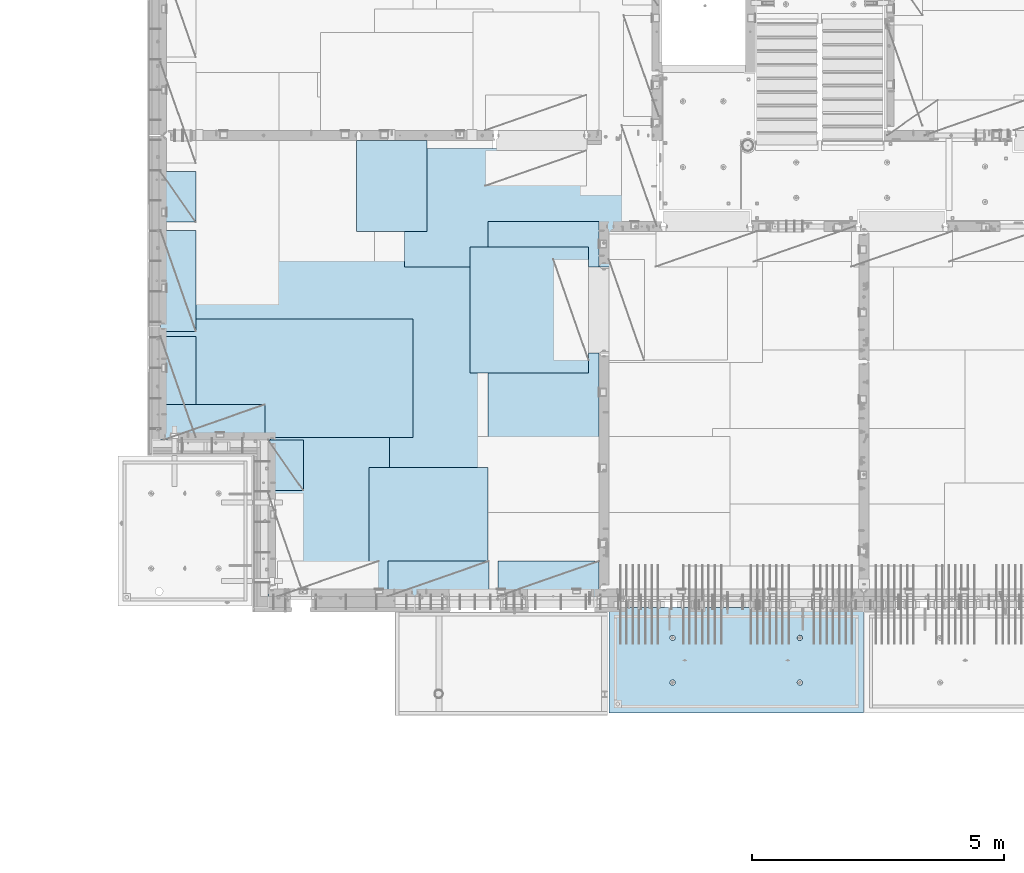
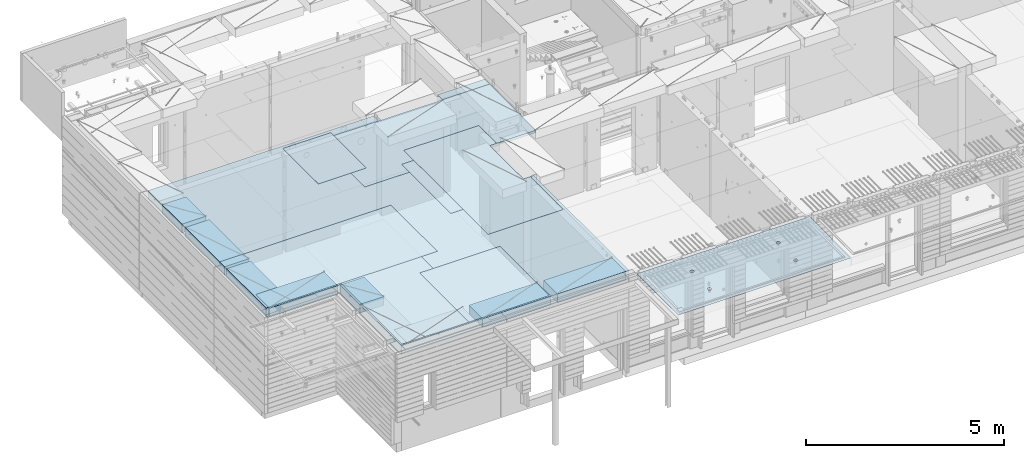
# One storey, part 179 of 325: 14 plates, 2 slabs, 14 elements without a shape of their own.
"""IFC2X3 building model written with IfcOpenShell, lengths in millimetres."""

from ifc_helpers import new_model, si_unit, frame, origin_with_axes, place, context, subcontext, project, spatial, faceted_brep, material, type_object, element, aggregate, save


model = new_model("IFC2X3")

# Units and contexts
model_context = context("Model", 3, precision=1e-05, world=origin_with_axes())
body_context = subcontext(model_context, "Body", "Model", "MODEL_VIEW")
ifc_project = project(units=[si_unit("LENGTHUNIT", "METRE", prefix="MILLI"), si_unit("AREAUNIT", "SQUARE_METRE"), si_unit("VOLUMEUNIT", "CUBIC_METRE"), si_unit("MASSUNIT", "GRAM", prefix="KILO"), si_unit("TIMEUNIT", "SECOND"), si_unit("PLANEANGLEUNIT", "RADIAN"), si_unit("SOLIDANGLEUNIT", "STERADIAN"), si_unit("THERMODYNAMICTEMPERATUREUNIT", "DEGREE_CELSIUS"), si_unit("LUMINOUSINTENSITYUNIT", "LUMEN")], contexts=[model_context])

# Site, building, storey
site_placement = place(None, origin_with_axes())
site = spatial("IfcSite", under=ifc_project, at=site_placement, CompositionType="ELEMENT")
building_placement = place(site_placement, origin_with_axes())
building = spatial("IfcBuilding", under=site, at=building_placement, CompositionType="ELEMENT")
storey_placement = place(building_placement, origin_with_axes())
storey = spatial("IfcBuildingStorey", under=building, at=storey_placement, Name="1", CompositionType="ELEMENT", Elevation=0.0)

# Assembly, slab
assembly_1_placement = place(storey_placement, origin_with_axes())
assembly_1 = element("IfcElementAssembly", 1, at=assembly_1_placement, inside=storey, AssemblyPlace="NOTDEFINED", PredefinedType="REINFORCEMENT_UNIT")
ifc_material_1 = material(Name="CONCRETE/C35/45")
slab_type_1 = type_object("IfcSlabType", PredefinedType="NOTDEFINED")
slab_1_placement = place(assembly_1_placement, frame((21799.9998568133, 7629.99655735226, 84720.0), z_axis=(-1.11800000013248e-06, -0.999999999999375, 0.0), x_axis=(-0.999999999999093, 1.34699999998405e-06, 0.0)))
slab_1 = element("IfcSlab", 2, at=slab_1_placement, type_object=slab_type_1, material=ifc_material_1, PredefinedType="FLOOR", context=body_context, shape_type="Brep", body=[
    faceted_brep([(3730.38290548735, -4.08996566387941, 616.12216176429), (3731.90567362447, 10.0, 615.627386703446), (3739.08833473806, 10.0, 629.724200466487), (3737.80580686752, -3.95055250760925, 630.656008831066), (3750.27560641379, 10.0, 640.911502705889), (3749.35118053074, -3.83997377335618, 642.183862123165), (3764.37240055375, 10.0, 648.094202331947), (3763.88889206625, -3.76900584615942, 649.582281527485), (3779.99882472937, 10.0, 650.569206660445), (3779.99882259584, -3.74455690493051, 652.131088126915), (3795.62525566664, 10.0, 648.094245023346), (3796.1087600739, -3.76900542440126, 649.582325494244), (3809.72206942968, 10.0, 640.911583909758), (3810.64649178305, -3.83997297089081, 642.183945778786), (3820.90937166908, 10.0, 629.724312234022), (3822.19189689232, -3.95055140258046, 630.656124028656), (3828.09207129514, 10.0, 615.627518094066), (3829.61483794004, -4.08996436404414, 616.122297269464), (3830.56707562364, 10.0, 600.001093918447), (3832.18578061358, -4.24460391153116, 600.001096129598), (3828.09211398654, 10.0, 584.374662981175), (3829.64831848373, -4.39934773846471, 583.869023838871), (3820.90945287295, 10.0, 570.277849218135), (3822.24608208202, -4.53903372617788, 569.306734043194), (3809.72218119721, 10.0, 559.090546978732), (3810.70070853473, -4.64994969953841, 557.743723511573), (3795.62538705726, 10.0, 551.907847352675), (3796.14233218844, -4.72119045964791, 550.316861227655), (3779.99896288164, 10.0, 549.432843024176), (3779.99896517058, -4.74574361447594, 547.757190340714), (3764.37253194437, 10.0, 551.907804661275), (3763.85559114489, -4.72119088313775, 550.316817078197), (3750.27571818133, 10.0, 559.090465774863), (3749.29719446955, -4.6499505048414, 557.743639560339), (3739.08841594193, 10.0, 570.277737450599), (3737.75178928409, -4.53903483404429, 569.306618549992), (3731.90571631587, 10.0, 584.374531590555), (3730.34951305942, -4.39934904004622, 583.868888150996), (3729.43071198737, 10.0, 600.000955766174), (3727.81200684201, -4.24460527917836, 600.000953555023), (0.0, 10.0, 0.0), (0.0, -10.0, 0.0), (0.000328360383718973, 10.0, 2085.00366210938), (5040.0, 10.0, -2.18278728425503e-09), (5040.0, -10.0, -2.18278728425503e-09), (5040.00048828125, 10.0, 2085.00366210938), (1210.18496592851, 4.0893025782425, 1468.8123736889), (1210.82376192895, 10.0, 1469.01993205604), (1208.29313952565, 10.0, 1484.99751183111), (1207.63911173254, 4.24455542066426, 1484.99751093771), (1217.61159442581, 3.94915724093153, 1454.20219661341), (1218.16787053537, 10.0, 1454.6063560253), (1229.19498209749, 3.837876675796, 1442.60117732261), (1229.60657282509, 10.0, 1443.16768498606), (1243.80127350603, 3.76640192835475, 1435.14992181469), (1244.02016891989, 10.0, 1435.82361575756), (1259.99775658, 3.74176842256566, 1432.58187432577), (1259.99775560856, 10.0, 1433.29303700502), (1276.19423262309, 3.76640235324157, 1435.14996610939), (1275.97533538363, 10.0, 1435.82365940832), (1290.8005036357, 3.83787748374743, 1442.60126155003), (1290.38891141437, 10.0, 1443.16776801473), (1302.38385956513, 3.94915835243592, 1454.20231248656), (1301.82758245361, 10.0, 1454.60647030446), (1309.81044810845, 4.08930388411682, 1468.81250982317), (1309.17165168211, 10.0, 1469.02006639926), (1312.35625807182, 4.244556792808, 1484.99765398133), (1311.70223043464, 10.0, 1484.99765308793), (1309.77685741928, 4.39970507899125, 1501.17189122433), (1309.17160803135, 10.0, 1500.975232863), (1302.32949611505, 4.53957668620569, 1515.75353188573), (1301.82749942493, 10.0, 1515.38880889374), (1290.74610851982, 4.65051890275208, 1527.31927827547), (1290.3887971352, 10.0, 1526.82747993297), (1276.16055006181, 4.72171992080985, 1534.74199744468), (1275.97520104041, 10.0, 1534.17154916147), (1259.99761353621, 4.74624887190294, 1537.29914508766), (1259.99761435174, 10.0, 1536.70212791401), (1243.83468398195, 4.72171949766926, 1534.74195333328), (1244.02003457667, 10.0, 1534.17150551072), (1229.24914576394, 4.65051809765282, 1527.31919434463), (1229.60645854592, 10.0, 1526.8273969043), (1217.66578971822, 4.53957557752437, 1515.75341630916), (1218.16778750669, 10.0, 1515.38869461457), (1210.21846821205, 4.39970377489226, 1501.17175527336), (1210.82371827819, 10.0, 1500.97509851978), (1210.34950957413, -4.39938207223895, 583.86544460908), (1211.90571640051, 10.0, 584.371089208588), (1209.43071207202, 10.0, 599.997513384207), (1207.81200317426, -4.24463830025343, 599.997511173051), (1217.75178633104, -4.53906787629239, 569.303173961003), (1219.08841602657, 10.0, 570.274295068632), (1229.29719234665, -4.64998355506395, 557.740194139937), (1230.27571826597, 10.0, 559.087023392896), (1243.85559006878, -4.72122393849713, 550.313371123784), (1244.37253202901, 10.0, 551.904362279308), (1259.99896525523, -4.74577667158155, 547.753744202259), (1259.99896296629, 10.0, 549.429400642209), (1276.14233343384, -4.72122351497819, 550.313415273247), (1275.6253871419, 10.0, 551.904404970708), (1290.70071082692, -4.64998274977552, 557.740278091178), (1289.72218128186, 10.0, 559.087104596765), (1302.24608520437, -4.53906676842598, 569.303289454215), (1300.9094529576, 10.0, 570.274406836168), (1309.64832213832, -4.39938077065744, 583.865580296964), (1308.09211407118, 10.0, 584.371220599208), (1312.18578445062, -4.24463693260623, 599.997653747636), (1310.56707570828, 10.0, 599.99765153648), (1309.61484159223, -4.08999737400154, 616.118856046664), (1308.09207137979, 10.0, 615.624075712099), (1302.19190001076, -3.95058440251159, 630.652683850883), (1300.90937175373, 10.0, 629.720869852055), (1290.64649407134, -3.8400059628766, 642.180506429899), (1289.72206951433, 10.0, 640.908141527791), (1276.10876131689, -3.76903841129388, 649.578886677323), (1275.62525575129, 10.0, 648.090802641378), (1259.99882268048, -3.74458989004779, 652.127649493255), (1259.99882481401, 10.0, 650.565764278478), (1243.88889099253, -3.76903883303748, 649.578842710559), (1244.37240063839, 10.0, 648.090759949978), (1229.35117841172, -3.84000676534197, 642.180422774271), (1230.27560649844, 10.0, 640.908060323922), (1217.80580391836, -3.95058550754038, 630.652568653284), (1219.0883348227, 10.0, 629.72075808452), (1210.38290200446, -4.08999867383682, 616.11872054148), (1211.90567370912, 10.0, 615.623944321479), (3795.97520095576, 10.0, 1534.17499154344), (3796.16054881881, 4.72175290768791, 1534.7454362616), (3779.99761345157, 4.74628185702022, 1537.30258372132), (3779.99761426709, 10.0, 1536.70557029598), (3810.38879705055, 10.0, 1526.83092231494), (3810.74610623151, 4.65055189473787, 1527.32271762435), (3821.82749934028, 10.0, 1515.39225127571), (3822.3294929966, 4.53960968612228, 1515.75697206351), (3829.1716079467, 10.0, 1500.97867524496), (3829.7768537671, 4.39973808894865, 1501.17533244712), (3831.70223035, 10.0, 1485.00109546989), (3832.35625423479, 4.24458981388307, 1485.00109636329), (3829.17165159746, 10.0, 1469.02350878122), (3829.81044445387, 4.08933691630955, 1468.81595336508), (3821.82758236896, 10.0, 1454.60991268643), (3822.38385644279, 3.94919139468402, 1454.20575707554), (3810.38891132972, 10.0, 1443.1712103967), (3810.8005013435, 3.83791053396999, 1442.60470697043), (3795.97533529899, 10.0, 1435.82710179029), (3796.19423137769, 3.76643540860096, 1435.1534120638), (3779.99775552391, 10.0, 1433.29647938699), (3779.99775649536, 3.74180147968582, 1432.58532046422), (3764.02016883524, 10.0, 1435.82705813953), (3763.80127458214, 3.76643498368503, 1435.1533677691), (3749.60657274045, 10.0, 1443.17112736803), (3749.19498422039, 3.837909726004, 1442.60462274301), (3738.16787045072, 10.0, 1454.60979840726), (3737.61159737886, 3.94919028317963, 1454.2056412024), (3730.82376184431, 10.0, 1469.023374438), (3730.18496941381, 4.08933561044978, 1468.81581723082), (3737.66579266739, 4.53960857747006, 1515.75685648694), (3749.24914788297, 4.65055108962406, 1527.32263369353), (3763.83468505566, 4.72175248454732, 1534.7453921502), (3727.63911540029, 4.24458844172477, 1485.00095331968), (3730.21847169495, 4.39973678484967, 1501.17519649617), (3764.02003449202, 10.0, 1534.17494789268), (3749.60645846128, 10.0, 1526.83083928627), (3738.16778742204, 10.0, 1515.39213699654), (3730.82371819355, 10.0, 1500.97854090175), (3728.293139441, 10.0, 1485.00095421308)], [[[0, 1, 2, 3]], [[3, 2, 4, 5]], [[5, 4, 6, 7]], [[7, 6, 8, 9]], [[10, 11, 9, 8]], [[12, 13, 11, 10]], [[14, 15, 13, 12]], [[16, 17, 15, 14]], [[18, 19, 17, 16]], [[20, 21, 19, 18]], [[22, 23, 21, 20]], [[24, 25, 23, 22]], [[26, 27, 25, 24]], [[27, 26, 28, 29]], [[29, 28, 30, 31]], [[31, 30, 32, 33]], [[33, 32, 34, 35]], [[35, 34, 36, 37]], [[37, 36, 38, 39]], [[39, 38, 1, 0]], [[40, 41, 42]], [[40, 43, 44, 41]], [[43, 45, 44]], [[46, 47, 48, 49]], [[50, 51, 47, 46]], [[52, 53, 51, 50]], [[54, 55, 53, 52]], [[56, 57, 55, 54]], [[58, 59, 57, 56]], [[60, 61, 59, 58]], [[61, 60, 62, 63]], [[63, 62, 64, 65]], [[65, 64, 66, 67]], [[67, 66, 68, 69]], [[69, 68, 70, 71]], [[71, 70, 72, 73]], [[73, 72, 74, 75]], [[75, 74, 76, 77]], [[77, 76, 78, 79]], [[80, 81, 79, 78]], [[82, 83, 81, 80]], [[84, 85, 83, 82]], [[49, 48, 85, 84]], [[86, 87, 88, 89]], [[90, 91, 87, 86]], [[92, 93, 91, 90]], [[94, 95, 93, 92]], [[96, 97, 95, 94]], [[98, 99, 97, 96]], [[99, 98, 100, 101]], [[101, 100, 102, 103]], [[103, 102, 104, 105]], [[105, 104, 106, 107]], [[107, 106, 108, 109]], [[109, 108, 110, 111]], [[111, 110, 112, 113]], [[113, 112, 114, 115]], [[115, 114, 116, 117]], [[118, 119, 117, 116]], [[120, 121, 119, 118]], [[122, 123, 121, 120]], [[124, 125, 123, 122]], [[89, 88, 125, 124]], [[126, 127, 128, 129]], [[130, 131, 127, 126]], [[132, 133, 131, 130]], [[134, 135, 133, 132]], [[136, 137, 135, 134]], [[138, 139, 137, 136]], [[140, 141, 139, 138]], [[142, 143, 141, 140]], [[143, 142, 144, 145]], [[145, 144, 146, 147]], [[147, 146, 148, 149]], [[149, 148, 150, 151]], [[151, 150, 152, 153]], [[153, 152, 154, 155]], [[41, 44, 45, 42], [3, 5, 7, 9, 11, 13, 15, 17, 19, 21, 23, 25, 27, 29, 31, 33, 35, 37, 39, 0], [156, 157, 158, 128, 127, 131, 133, 135, 137, 139, 141, 143, 145, 147, 149, 151, 153, 155, 159, 160], [122, 120, 118, 116, 114, 112, 110, 108, 106, 104, 102, 100, 98, 96, 94, 92, 90, 86, 89, 124], [82, 80, 78, 76, 74, 72, 70, 68, 66, 64, 62, 60, 58, 56, 54, 52, 50, 46, 49, 84]], [[129, 128, 158, 161]], [[157, 162, 161, 158]], [[156, 163, 162, 157]], [[160, 164, 163, 156]], [[159, 165, 164, 160]], [[155, 154, 165, 159]], [[43, 40, 42, 45], [34, 32, 30, 28, 26, 24, 22, 20, 18, 16, 14, 12, 10, 8, 6, 4, 2, 1, 38, 36], [152, 150, 148, 146, 144, 142, 140, 138, 136, 134, 132, 130, 126, 129, 161, 162, 163, 164, 165, 154], [91, 93, 95, 97, 99, 101, 103, 105, 107, 109, 111, 113, 115, 117, 119, 121, 123, 125, 88, 87], [51, 53, 55, 57, 59, 61, 63, 65, 67, 69, 71, 73, 75, 77, 79, 81, 83, 85, 48, 47]]]),
])
aggregate(assembly_1, [slab_1])

# Assembly, plate
assembly_2_placement = place(storey_placement, origin_with_axes())
assembly_2 = element("IfcElementAssembly", 3, at=assembly_2_placement, inside=storey, Name="Steel Assembly", AssemblyPlace="NOTDEFINED", PredefinedType="NOTDEFINED")
ifc_material_2 = material()
plate_type_1 = type_object("IfcPlateType", PredefinedType="NOTDEFINED")
plate_1_placement = place(assembly_2_placement, frame((14009.7695320312, 12275.0000289158, 84695.1), z_axis=(0.0, 1.0, 0.0), x_axis=(1.0, 0.0, 0.0)))
plate_1 = element("IfcPlate", 4, at=plate_1_placement, type_object=plate_type_1, material=ifc_material_2, Name="1/2", context=body_context, shape_type="Brep", body=[
    faceted_brep([(0.0, -35.0, 0.0), (0.0, -35.0, 2500.0), (0.0, 35.0, 2500.0), (0.0, 35.0, 0.0), (2349.99951171875, -35.0, 2500.0), (2349.99951171875, 35.0, 2500.0), (2350.0, -35.0, 0.0), (2350.0, 35.0, 0.0)], [[[0, 1, 2, 3]], [[1, 4, 5, 2]], [[4, 6, 7, 5]], [[6, 0, 3, 7]], [[5, 7, 3, 2]], [[6, 4, 1, 0]]]),
])
aggregate(assembly_2, [plate_1])

assembly_3_placement = place(storey_placement, origin_with_axes())
assembly_3 = element("IfcElementAssembly", 5, at=assembly_3_placement, inside=storey, Name="Steel Assembly", AssemblyPlace="NOTDEFINED", PredefinedType="NOTDEFINED")
plate_2_placement = place(assembly_3_placement, frame((14360.0, 10400.0, 84695.1), z_axis=(0.0, -1.0, 0.0), x_axis=(-1.0, 3.00000001838171e-08, 0.0)))
plate_2 = element("IfcPlate", 6, at=plate_2_placement, type_object=plate_type_1, material=ifc_material_2, Name="1/2", context=body_context, shape_type="Brep", body=[
    faceted_brep([(0.0, -35.0, 0.0), (0.0, -35.0, 2500.0), (0.0, 35.0, 2500.0), (0.0, 35.0, 0.0), (2349.99951171875, -35.0, 2500.0), (2349.99951171875, 35.0, 2500.0), (2350.0, -35.0, 0.0), (2350.0, 35.0, 0.0)], [[[0, 1, 2, 3]], [[1, 4, 5, 2]], [[4, 6, 7, 5]], [[6, 0, 3, 7]], [[5, 7, 3, 2]], [[6, 4, 1, 0]]]),
])
aggregate(assembly_3, [plate_2])

assembly_4_placement = place(storey_placement, origin_with_axes())
assembly_4 = element("IfcElementAssembly", 7, at=assembly_4_placement, inside=storey, Name="Steel Assembly", AssemblyPlace="NOTDEFINED", PredefinedType="NOTDEFINED")
plate_3_placement = place(assembly_4_placement, frame((12710.0, 16725.0, 84695.1), z_axis=(1.0, 0.0, 0.0), x_axis=(0.0, -1.0, 0.0)))
plate_3 = element("IfcPlate", 8, at=plate_3_placement, type_object=plate_type_1, material=ifc_material_2, context=body_context, shape_type="Brep", body=[
    faceted_brep([(0.0, -35.0, 0.0), (0.0, -35.0, 5000.0), (0.0, 35.0, 5000.0), (0.0, 35.0, 0.0), (2349.99951171875, -35.0, 5000.0), (2349.99951171875, 35.0, 5000.0), (2350.0, -35.0, 0.0), (2350.0, 35.0, 0.0)], [[[0, 1, 2, 3]], [[1, 4, 5, 2]], [[4, 6, 7, 5]], [[6, 0, 3, 7]], [[5, 7, 3, 2]], [[6, 4, 1, 0]]]),
])
aggregate(assembly_4, [plate_3])

assembly_5_placement = place(storey_placement, origin_with_axes())
assembly_5 = element("IfcElementAssembly", 9, at=assembly_5_placement, inside=storey, Name="Steel Assembly", AssemblyPlace="NOTDEFINED", PredefinedType="NOTDEFINED")
plate_4_placement = place(assembly_5_placement, frame((10060.0, 7900.0, 84695.1), z_axis=(0.0, 1.0, 0.0), x_axis=(1.0, 0.0, 0.0)))
plate_4 = element("IfcPlate", 10, at=plate_4_placement, type_object=plate_type_1, material=ifc_material_2, context=body_context, shape_type="Brep", body=[
    faceted_brep([(0.0, -35.0, 0.0), (0.0, -35.0, 5000.0), (0.0, 35.0, 5000.0), (0.0, 35.0, 0.0), (2349.99951171875, -35.0, 5000.0), (2349.99951171875, 35.0, 5000.0), (2350.0, -35.0, 0.0), (2350.0, 35.0, 0.0)], [[[0, 1, 2, 3]], [[1, 4, 5, 2]], [[4, 6, 7, 5]], [[6, 0, 3, 7]], [[5, 7, 3, 2]], [[6, 4, 1, 0]]]),
])
aggregate(assembly_5, [plate_4])

assembly_6_placement = place(storey_placement, origin_with_axes())
assembly_6 = element("IfcElementAssembly", 11, at=assembly_6_placement, inside=storey, Name="Steel Assembly", AssemblyPlace="NOTDEFINED", PredefinedType="NOTDEFINED")
plate_5_placement = place(assembly_6_placement, frame((12880.0, 11000.0, 84695.1), z_axis=(-1.0, 3.00000001838171e-08, 0.0), x_axis=(0.0, 1.0, 0.0)))
plate_5 = element("IfcPlate", 12, at=plate_5_placement, type_object=plate_type_1, material=ifc_material_2, context=body_context, shape_type="Brep", body=[
    faceted_brep([(0.0, -35.0, 0.0), (0.0, -35.0, 5000.0), (0.0, 35.0, 5000.0), (0.0, 35.0, 0.0), (2349.99951171875, -35.0, 5000.0), (2349.99951171875, 35.0, 5000.0), (2350.0, -35.0, 0.0), (2350.0, 35.0, 0.0)], [[[0, 1, 2, 3]], [[1, 4, 5, 2]], [[4, 6, 7, 5]], [[6, 0, 3, 7]], [[5, 7, 3, 2]], [[6, 4, 1, 0]]]),
])
aggregate(assembly_6, [plate_5])

assembly_7_placement = place(storey_placement, origin_with_axes())
assembly_7 = element("IfcElementAssembly", 13, at=assembly_7_placement, inside=storey, Name="Steel Assembly", AssemblyPlace="NOTDEFINED", PredefinedType="NOTDEFINED")
plate_type_2 = type_object("IfcPlateType", PredefinedType="NOTDEFINED")
plate_6_placement = place(assembly_7_placement, frame((7879.99987792969, 13000.0, 84595.3), z_axis=(1.0, 0.0, 0.0), x_axis=(0.0, -1.0, 0.0)))
plate_6 = element("IfcPlate", 14, at=plate_6_placement, type_object=plate_type_2, material=ifc_material_2, Name="RE1", context=body_context, shape_type="Brep", body=[
    faceted_brep([(1.81898940354586e-12, -135.0, 1.81898940354586e-12), (0.0, -135.0, 699.999999999996), (0.0, 135.0, 699.999999999996), (1.81898940354586e-12, 135.0, 1.81898940354586e-12), (1999.99951171875, -135.0, 699.999999999993), (1999.99951171875, 135.0, 699.999999999993), (2000.0, -135.0, -3.63797880709171e-12), (2000.0, 135.0, -3.63797880709171e-12)], [[[0, 1, 2, 3]], [[1, 4, 5, 2]], [[4, 6, 7, 5]], [[6, 0, 3, 7]], [[5, 7, 3, 2]], [[6, 4, 1, 0]]]),
])
aggregate(assembly_7, [plate_6])

assembly_8_placement = place(storey_placement, origin_with_axes())
assembly_8 = element("IfcElementAssembly", 15, at=assembly_8_placement, inside=storey, Name="Steel Assembly", AssemblyPlace="NOTDEFINED", PredefinedType="NOTDEFINED")
plate_7_placement = place(assembly_8_placement, frame((7945.00085423865, 10950.0001036336, 84595.3), z_axis=(0.0, 1.0, 0.0), x_axis=(1.0, 0.0, 0.0)))
plate_7 = element("IfcPlate", 16, at=plate_7_placement, type_object=plate_type_2, material=ifc_material_2, Name="RE1", context=body_context, shape_type="Brep", body=[
    faceted_brep([(1.81898940354586e-12, -135.0, 1.81898940354586e-12), (0.0, -135.0, 699.999999999996), (0.0, 135.0, 699.999999999996), (1.81898940354586e-12, 135.0, 1.81898940354586e-12), (1999.99951171875, -135.0, 699.999999999993), (1999.99951171875, 135.0, 699.999999999993), (2000.0, -135.0, -3.63797880709171e-12), (2000.0, 135.0, -3.63797880709171e-12)], [[[0, 1, 2, 3]], [[1, 4, 5, 2]], [[4, 6, 7, 5]], [[6, 0, 3, 7]], [[5, 7, 3, 2]], [[6, 4, 1, 0]]]),
])
aggregate(assembly_8, [plate_7])

assembly_9_placement = place(storey_placement, origin_with_axes())
assembly_9 = element("IfcElementAssembly", 17, at=assembly_9_placement, inside=storey, Name="Steel Assembly", AssemblyPlace="NOTDEFINED", PredefinedType="NOTDEFINED")
plate_8_placement = place(assembly_9_placement, frame((10009.9999999293, 10950.0, 84595.3), z_axis=(1.0, 0.0, 0.0), x_axis=(0.0, -1.0, 0.0)))
plate_8 = element("IfcPlate", 18, at=plate_8_placement, type_object=plate_type_2, material=ifc_material_2, Name="RE1_1/2", context=body_context, shape_type="Brep", body=[
    faceted_brep([(1.81898940354586e-12, -135.0, 1.81898940354586e-12), (0.0, -135.0, 699.999999999996), (0.0, 135.0, 699.999999999996), (1.81898940354586e-12, 135.0, 1.81898940354586e-12), (999.99951171875, -135.0, 700.0), (999.99951171875, 135.0, 700.0), (1000.0, -135.0, 0.0), (1000.0, 135.0, 0.0)], [[[0, 1, 2, 3]], [[1, 4, 5, 2]], [[4, 6, 7, 5]], [[6, 0, 3, 7]], [[5, 7, 3, 2]], [[6, 4, 1, 0]]]),
])
aggregate(assembly_9, [plate_8])

assembly_10_placement = place(storey_placement, origin_with_axes())
assembly_10 = element("IfcElementAssembly", 19, at=assembly_10_placement, inside=storey, Name="Steel Assembly", AssemblyPlace="NOTDEFINED", PredefinedType="NOTDEFINED")
plate_9_placement = place(assembly_10_placement, frame((7879.99999992931, 16265.0, 84595.3), z_axis=(1.0, 0.0, 0.0), x_axis=(0.0, -1.0, 0.0)))
plate_9 = element("IfcPlate", 20, at=plate_9_placement, type_object=plate_type_2, material=ifc_material_2, Name="RE1_1/2", context=body_context, shape_type="Brep", body=[
    faceted_brep([(1.81898940354586e-12, -135.0, 1.81898940354586e-12), (0.0, -135.0, 699.999999999996), (0.0, 135.0, 699.999999999996), (1.81898940354586e-12, 135.0, 1.81898940354586e-12), (999.99951171875, -135.0, 700.0), (999.99951171875, 135.0, 700.0), (1000.0, -135.0, 0.0), (1000.0, 135.0, 0.0)], [[[0, 1, 2, 3]], [[1, 4, 5, 2]], [[4, 6, 7, 5]], [[6, 0, 3, 7]], [[5, 7, 3, 2]], [[6, 4, 1, 0]]]),
])
aggregate(assembly_10, [plate_9])

assembly_11_placement = place(storey_placement, origin_with_axes())
assembly_11 = element("IfcElementAssembly", 21, at=assembly_11_placement, inside=storey, Name="Steel Assembly", AssemblyPlace="NOTDEFINED", PredefinedType="NOTDEFINED")
plate_10_placement = place(assembly_11_placement, frame((14565.0008542386, 7850.00010363356, 84595.3), z_axis=(0.0, 1.0, 0.0), x_axis=(1.0, 0.0, 0.0)))
plate_10 = element("IfcPlate", 22, at=plate_10_placement, type_object=plate_type_2, material=ifc_material_2, Name="RE1", context=body_context, shape_type="Brep", body=[
    faceted_brep([(1.81898940354586e-12, -135.0, 1.81898940354586e-12), (0.0, -135.0, 699.999999999996), (0.0, 135.0, 699.999999999996), (1.81898940354586e-12, 135.0, 1.81898940354586e-12), (1999.99951171875, -135.0, 699.999999999993), (1999.99951171875, 135.0, 699.999999999993), (2000.0, -135.0, -3.63797880709171e-12), (2000.0, 135.0, -3.63797880709171e-12)], [[[0, 1, 2, 3]], [[1, 4, 5, 2]], [[4, 6, 7, 5]], [[6, 0, 3, 7]], [[5, 7, 3, 2]], [[6, 4, 1, 0]]]),
])
aggregate(assembly_11, [plate_10])

assembly_12_placement = place(storey_placement, origin_with_axes())
assembly_12 = element("IfcElementAssembly", 23, at=assembly_12_placement, inside=storey, Name="Steel Assembly", AssemblyPlace="NOTDEFINED", PredefinedType="NOTDEFINED")
plate_11_placement = place(assembly_12_placement, frame((12382.5008542386, 7850.00010363356, 84595.3), z_axis=(0.0, 1.0, 0.0), x_axis=(1.0, 0.0, 0.0)))
plate_11 = element("IfcPlate", 24, at=plate_11_placement, type_object=plate_type_2, material=ifc_material_2, Name="RE1", context=body_context, shape_type="Brep", body=[
    faceted_brep([(1.81898940354586e-12, -135.0, 1.81898940354586e-12), (0.0, -135.0, 699.999999999996), (0.0, 135.0, 699.999999999996), (1.81898940354586e-12, 135.0, 1.81898940354586e-12), (1999.99951171875, -135.0, 699.999999999993), (1999.99951171875, 135.0, 699.999999999993), (2000.0, -135.0, -3.63797880709171e-12), (2000.0, 135.0, -3.63797880709171e-12)], [[[0, 1, 2, 3]], [[1, 4, 5, 2]], [[4, 6, 7, 5]], [[6, 0, 3, 7]], [[5, 7, 3, 2]], [[6, 4, 1, 0]]]),
])
aggregate(assembly_12, [plate_11])

assembly_13_placement = place(storey_placement, origin_with_axes())
assembly_13 = element("IfcElementAssembly", 25, at=assembly_13_placement, inside=storey, Name="Steel Assembly", AssemblyPlace="NOTDEFINED", PredefinedType="NOTDEFINED")
plate_12_placement = place(assembly_13_placement, frame((7879.99987792969, 15100.0, 84595.3), z_axis=(1.0, 0.0, 0.0), x_axis=(0.0, -1.0, 0.0)))
plate_12 = element("IfcPlate", 26, at=plate_12_placement, type_object=plate_type_2, material=ifc_material_2, Name="RE1", context=body_context, shape_type="Brep", body=[
    faceted_brep([(1.81898940354586e-12, -135.0, 1.81898940354586e-12), (0.0, -135.0, 699.999999999996), (0.0, 135.0, 699.999999999996), (1.81898940354586e-12, 135.0, 1.81898940354586e-12), (1999.99951171875, -135.0, 699.999999999993), (1999.99951171875, 135.0, 699.999999999993), (2000.0, -135.0, -3.63797880709171e-12), (2000.0, 135.0, -3.63797880709171e-12)], [[[0, 1, 2, 3]], [[1, 4, 5, 2]], [[4, 6, 7, 5]], [[6, 0, 3, 7]], [[5, 7, 3, 2]], [[6, 4, 1, 0]]]),
])
aggregate(assembly_13, [plate_12])

# Assembly, plates, slab
assembly_14_placement = place(storey_placement, origin_with_axes())
assembly_14 = element("IfcElementAssembly", 27, at=assembly_14_placement, inside=storey, AssemblyPlace="NOTDEFINED", PredefinedType="REINFORCEMENT_UNIT")
plate_type_3 = type_object("IfcPlateType", PredefinedType="NOTDEFINED")
plate_13_placement = place(assembly_14_placement, frame((13159.9998642727, 15079.9997757405, 84725.45), z_axis=(-1.0, 3.00000001838171e-08, 0.0), x_axis=(0.0, 1.0, 0.0)))
plate_13 = element("IfcPlate", 28, at=plate_13_placement, type_object=plate_type_3, material=ifc_material_2, context=body_context, shape_type="Brep", body=[
    faceted_brep([(0.0, -5.0, 0.0), (0.0, -5.0, 1399.99963378906), (0.0, 5.0, 1399.99963378906), (0.0, 5.0, 0.0), (1800.00024414063, -5.0, 1399.99963378906), (1800.00024414063, 5.0, 1399.99963378906), (1800.00024414063, -5.0, 0.0), (1800.00024414063, 5.0, 0.0)], [[[0, 1, 2, 3]], [[1, 4, 5, 2]], [[4, 6, 7, 5]], [[6, 0, 3, 7]], [[5, 7, 3, 2]], [[6, 4, 1, 0]]]),
])
plate_type_4 = type_object("IfcPlateType", PredefinedType="NOTDEFINED")
plate_14_placement = place(assembly_14_placement, frame((16559.9994828029, 15279.9995850056, 84725.45), z_axis=(0.0, -1.0, 0.0), x_axis=(-1.0, 3.00000001838171e-08, 0.0)))
plate_14 = element("IfcPlate", 29, at=plate_14_placement, type_object=plate_type_4, material=ifc_material_2, context=body_context, shape_type="Brep", body=[
    faceted_brep([(0.0, -5.0, 2604.99950854713), (0.0, 5.0, 2604.99950854713), (200.234115600586, 5.0, 2604.99950854713), (200.234115600586, -5.0, 2604.99950854713), (200.234115600586, 5.0, 904.999508547127), (200.234115600586, -5.0, 904.999508547127), (0.0, -5.0, 904.999508547127), (0.0, 5.0, 904.999508547127), (0.0, -5.0, 4271.99951171875), (2191.99951171875, -5.0, 4271.99951171875), (2191.99951171875, 5.0, 4271.99951171875), (0.0, 5.0, 4271.99951171875), (2191.99951171875, -5.0, 0.0), (2191.99951171875, 5.0, 0.0), (0.0, -5.0, 0.0), (0.0, 5.0, 0.0)], [[[0, 1, 2, 3]], [[3, 2, 4, 5]], [[6, 5, 4, 7]], [[8, 9, 10, 11]], [[9, 12, 13, 10]], [[12, 14, 15, 13]], [[15, 14, 6, 7]], [[2, 1, 11, 10, 13, 15, 7, 4]], [[8, 11, 1, 0]], [[14, 12, 9, 8, 0, 3, 5, 6]]]),
])
ifc_material_3 = material(Name="CONCRETE/C30/37")
slab_type_2 = type_object("IfcSlabType", PredefinedType="NOTDEFINED")
slab_2_placement = place(assembly_14_placement, frame((10010.0, 7850.0, 84595.0), z_axis=(0.0, 1.0, 0.0), x_axis=(1.0, 0.0, 0.0)))
slab_2 = element("IfcSlab", 30, at=slab_2_placement, type_object=slab_type_2, material=ifc_material_3, PredefinedType="FLOOR", context=body_context, shape_type="Brep", body=[
    faceted_brep([(4453.68914550781, -135.0, 9130.0), (-2130.0, -135.0, 9130.0), (-2130.0, -135.0, 3100.0), (0.0, -135.0, 3100.0), (1.81898940354586e-12, -135.0, 1.81898940354586e-12), (6650.0, -135.0, 0.0), (6650.0, -135.0, 4825.00007645847), (6349.76536720235, -135.0, 4825.00007645847), (6349.76536720235, -135.0, 6525.00007645847), (6649.99998634297, -135.0, 6525.00007645847), (6650.0, -135.0, 7330.0), (7700.0, -135.0, 7330.0), (7700.0, -135.0, 9130.0), (6319.99914550781, -135.0, 9130.0), (6319.99914550781, -135.0, 8830.0), (6153.68914550781, -135.0, 8830.0), (4520.0, -135.0, 8830.0), (4453.69, -135.0, 8830.0), (-2130.0, 135.0, 9130.0), (4453.68914550781, 135.0, 9130.0), (-2130.0, 135.0, 3100.0), (0.0, 135.0, 3100.0), (1.81898940354586e-12, 135.0, 1.81898940354586e-12), (6650.0, 135.0, 0.0), (6650.0, 135.0, 4825.00007645847), (6349.76536720235, 135.0, 4825.00007645847), (6349.76536720235, 135.0, 6525.00007645847), (6650.0, 135.0, 6525.00007645847), (6650.0, 135.0, 7330.0), (7700.0, 135.0, 7330.0), (7700.0, 135.0, 9130.0), (6319.99914550781, 135.0, 9130.0), (6319.99914550781, 135.0, 8830.0), (6153.68914550781, 135.0, 8830.0), (4520.0, 135.0, 8830.0), (4453.69, 135.0, 8830.0)], [[[0, 1, 2, 3, 4, 5, 6, 7, 8, 9, 10, 11, 12, 13, 14, 15, 16, 17]], [[18, 1, 0, 19]], [[2, 1, 18, 20]], [[3, 2, 20, 21]], [[4, 3, 21, 22]], [[5, 4, 22, 23]], [[5, 23, 24, 6]], [[6, 24, 25, 7]], [[7, 25, 26, 8]], [[9, 8, 26, 27]], [[28, 10, 9, 27]], [[11, 10, 28, 29]], [[12, 11, 29, 30]], [[12, 30, 31, 13]], [[13, 31, 32, 14]], [[15, 14, 32, 33, 34, 16]], [[16, 34, 35, 17]], [[33, 32, 31, 30, 29, 28, 27, 26, 25, 24, 23, 22, 21, 20, 18, 19, 35, 34]], [[0, 17, 35, 19]]]),
])
aggregate(assembly_14, [plate_13, plate_14, slab_2])

save(model, "model.ifc")
